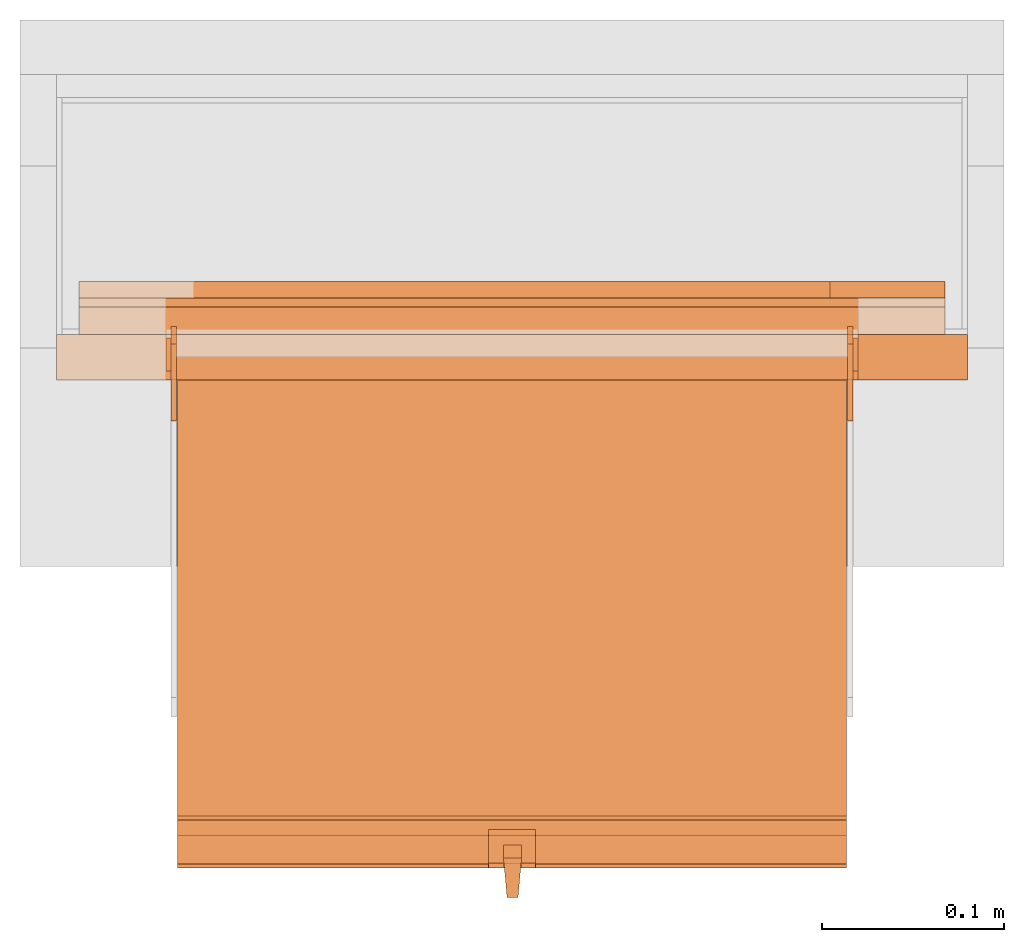
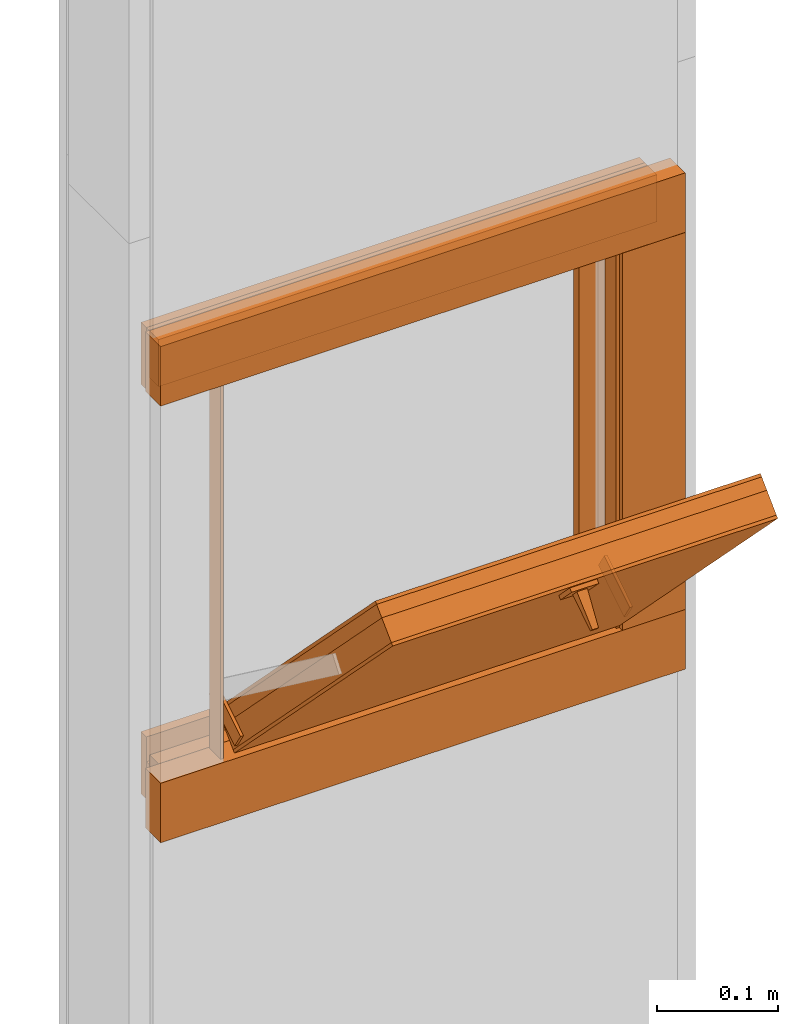
# One storey, part 2 of 3: 20 proxies.
"""IFC2X3 building model written with IfcOpenShell, lengths in metres."""

from ifc_helpers import new_model, entity, si_unit, converted_unit, derived_unit, money_unit, direction, frame, origin_with_axes, place, context, subcontext, project, spatial, polyline, outline, extrude, faceted_brep, source, transform, mapped, material, type_object, element, save


model = new_model("IFC2X3")

# Units and contexts
model_context = context("Model", 3, precision=1e-05, world=origin_with_axes(), true_north=direction((0.0, 1.0)))
plan_context = context("Plan", 3, precision=1e-05, world=origin_with_axes(), true_north=direction((0.0, 1.0)))
body_context = subcontext(model_context, "Body", "Model", "MODEL_VIEW")
ifc_project = project(units=[si_unit("LENGTHUNIT", "METRE"), si_unit("AREAUNIT", "SQUARE_METRE"), si_unit("VOLUMEUNIT", "CUBIC_METRE"), converted_unit("PLANEANGLEUNIT", "DEGREE", entity("IfcPlaneAngleMeasure", 0.0174532925199), si_unit("PLANEANGLEUNIT", "RADIAN"), dimensions=[0, 0, 0, 0, 0, 0, 0]), si_unit("SOLIDANGLEUNIT", "STERADIAN"), money_unit("CHF"), converted_unit("TIMEUNIT", "Year", entity("IfcTimeMeasure", 31556926.0), si_unit("TIMEUNIT", "SECOND"), dimensions=[0, 0, 1, 0, 0, 0, 0]), si_unit("MASSUNIT", "GRAM", prefix="KILO"), si_unit("THERMODYNAMICTEMPERATUREUNIT", "DEGREE_CELSIUS"), si_unit("LUMINOUSINTENSITYUNIT", "LUMEN"), si_unit("ENERGYUNIT", "JOULE", prefix="MEGA"), derived_unit("THERMALCONDUCTANCEUNIT", [(si_unit("POWERUNIT", "WATT"), 1), (si_unit("LENGTHUNIT", "METRE"), -1), (si_unit("THERMODYNAMICTEMPERATUREUNIT", "KELVIN"), -1)]), derived_unit("SPECIFICHEATCAPACITYUNIT", [(si_unit("ENERGYUNIT", "JOULE"), 1), (si_unit("MASSUNIT", "GRAM", prefix="KILO"), -1), (si_unit("THERMODYNAMICTEMPERATUREUNIT", "KELVIN"), -1)]), derived_unit("MASSDENSITYUNIT", [(si_unit("MASSUNIT", "GRAM", prefix="KILO"), 1), (si_unit("VOLUMEUNIT", "CUBIC_METRE"), -1)])], contexts=[model_context, plan_context])

# Site, building, storey
site_placement = place(None, origin_with_axes())
site = spatial("IfcSite", under=ifc_project, at=site_placement, CompositionType="ELEMENT")
building_placement = place(site_placement, origin_with_axes())
building = spatial("IfcBuilding", under=site, at=building_placement, CompositionType="ELEMENT")
storey_placement = place(building_placement, origin_with_axes())
storey = spatial("IfcBuildingStorey", under=building, at=storey_placement, Name="EG00", CompositionType="ELEMENT", Elevation=0.0)

# Proxies
ifc_material_1 = material(Name="Holz")
building_element_proxy_type_1 = type_object("IfcBuildingElementProxyType", Name="Holz 15", PredefinedType="NOTDEFINED")
for number, where, z_axis, x_axis, name in (
    (1, (9.60272436818, -3.87378861887, 0.99), (0.0, 0.0, 1.0), (-1.0, 0.0, 0.0), "Wand-004"),
    (2, (9.60272436818, -3.87378861887, 0.5625), (0.0, 0.0, 1.0), (-1.0, 0.0, 0.0), "Wand-004"),
):
    element("IfcBuildingElementProxy", number, at=place(storey_placement, frame(where, z_axis=z_axis, x_axis=x_axis)), inside=storey, type_object=building_element_proxy_type_1, material=ifc_material_1, Name=name, context=body_context, shape_type="SweptSolid", body=[
        extrude(outline(polyline([(0.0, 0.0), (0.475, 0.0), (0.475, 0.015), (0.0, 0.015), (0.0, 0.0)])), origin_with_axes(), (0.0, 0.0, 1.0), 0.0475),
    ])
building_element_proxy_type_2 = type_object("IfcBuildingElementProxyType", Name="Holz 25", PredefinedType="NOTDEFINED")
proxy_1_placement = place(storey_placement, frame((9.55522436818, -3.91378861887, 0.61), z_axis=(0.0, 0.0, 1.0), x_axis=(1.0, 0.0, 0.0)))
element("IfcBuildingElementProxy", 3, at=proxy_1_placement, inside=storey, type_object=building_element_proxy_type_2, material=ifc_material_1, Name="Wand-004", context=body_context, shape_type="SweptSolid", body=[
    extrude(outline(polyline([(0.0, 0.0), (0.06, 0.0), (0.06, 0.025), (0.0, 0.025), (0.0, 0.0)])), origin_with_axes(), (0.0, 0.0, 1.0), 0.38),
])
for number, where, z_axis, x_axis, name in (
    (4, (9.61522436818, -3.88878861887, 0.99), (0.0, 0.0, 1.0), (-1.0, 0.0, 0.0), "Wand-004"),
    (5, (9.61522436818, -3.88878861887, 0.55), (0.0, 0.0, 1.0), (-1.0, 0.0, 0.0), "Wand-004"),
):
    element("IfcBuildingElementProxy", number, at=place(storey_placement, frame(where, z_axis=z_axis, x_axis=x_axis)), inside=storey, type_object=building_element_proxy_type_2, material=ifc_material_1, Name=name, context=body_context, shape_type="SweptSolid", body=[
        extrude(outline(polyline([(0.0, 0.0), (0.5, 0.0), (0.5, 0.025), (0.0, 0.025), (0.0, 0.0)])), origin_with_axes(), (0.0, 0.0, 1.0), 0.06),
    ])
ifc_material_2 = material(Name="Metall, Aluminium")
building_element_proxy_type_3 = type_object("IfcBuildingElementProxyType", Name="Metall, Aluminium", PredefinedType="NOTDEFINED")
shared_shape_1 = source(origin_with_axes(), body_context, "Body", "Brep", [
    faceted_brep([(16.1345115895, -3.59726483298, 0.726478855326), (16.1345115895, -3.60026483298, 0.726478855326), (16.1345115895, -3.60026483298, 0.776478855326), (16.1345115895, -3.59726483298, 0.776478855326), (16.1525115895, -3.60026483298, 0.726478855326), (16.1525115895, -3.59726483298, 0.726478855326), (16.1525115895, -3.60026483298, 0.776478855326), (16.1525115895, -3.59726483298, 0.776478855326)], [[[0, 1, 2, 3]], [[4, 1, 0, 5]], [[1, 4, 6, 2]], [[2, 6, 7, 3]], [[0, 3, 7, 5]], [[4, 5, 7, 6]]]),
])
for number, where, z_axis, x_axis, name in (
    (6, (12.7784892012, -11.8786678245, 14.7145311427), (0.0, -0.846133712697, -0.532970674838), (0.0, 0.532970674838, -0.846133712697), "Wand-005"),
    (7, (13.1494892012, -11.8786678245, 14.7145311427), (0.0, -0.846133712697, -0.532970674838), (0.0, 0.532970674838, -0.846133712697), "Wand-005"),
):
    element("IfcBuildingElementProxy", number, at=place(storey_placement, frame(where, z_axis=z_axis, x_axis=x_axis)), inside=storey, type_object=building_element_proxy_type_3, material=ifc_material_2, Name=name, context=body_context, shape_type="MappedRepresentation", body=[
        mapped(shared_shape_1, transform((0.0, 0.0, 0.0))),
    ])
building_element_proxy_type_4 = type_object("IfcBuildingElementProxyType", Name="Holz 5", PredefinedType="NOTDEFINED")
for number, where, z_axis, x_axis, name in (
    (8, (9.60272436818, -3.87378861887, 1.0), (0.0, 0.0, 1.0), (-1.0, 0.0, 0.0), "Wand-004"),
    (9, (9.60272436818, -3.87378861887, 0.5625), (0.0, 0.0, 1.0), (-1.0, 0.0, 0.0), "Wand-004"),
):
    element("IfcBuildingElementProxy", number, at=place(storey_placement, frame(where, z_axis=z_axis, x_axis=x_axis)), inside=storey, type_object=building_element_proxy_type_4, material=ifc_material_1, Name=name, context=body_context, shape_type="SweptSolid", body=[
        extrude(outline(polyline([(0.0, -0.005), (0.475, -0.005), (0.475, 0.0), (0.0, 0.0), (0.0, -0.005)])), origin_with_axes(), (0.0, 0.0, 1.0), 0.0375),
    ])
building_element_proxy_type_5 = type_object("IfcBuildingElementProxyType", Name="Holz 9", PredefinedType="NOTDEFINED")
proxy_2_placement = place(storey_placement, frame((9.53972436818, -3.86878861887, 0.625), z_axis=(0.0, 0.0, 1.0), x_axis=(1.0, 0.0, 0.0)))
element("IfcBuildingElementProxy", 10, at=proxy_2_placement, inside=storey, type_object=building_element_proxy_type_5, material=ifc_material_1, Name="Wand-004", context=body_context, shape_type="SweptSolid", body=[
    extrude(outline(polyline([(0.0, 0.0), (0.063, 0.0), (0.063, 0.009), (0.0, 0.009), (0.0, 0.0)])), origin_with_axes(), (0.0, 0.0, 1.0), 0.35),
])
for number, where, z_axis, x_axis, name in (
    (11, (9.60272436818, -3.86878861887, 0.975), (0.0, 0.0, 1.0), (-1.0, 0.0, 0.0), "Wand-004"),
    (12, (9.60272436818, -3.86878861887, 0.5625), (0.0, 0.0, 1.0), (-1.0, 0.0, 0.0), "Wand-004"),
):
    element("IfcBuildingElementProxy", number, at=place(storey_placement, frame(where, z_axis=z_axis, x_axis=x_axis)), inside=storey, type_object=building_element_proxy_type_5, material=ifc_material_1, Name=name, context=body_context, shape_type="SweptSolid", body=[
        extrude(outline(polyline([(0.0, -0.009), (0.475, -0.009), (0.475, 0.0), (0.0, 0.0), (0.0, -0.009)])), origin_with_axes(), (0.0, 0.0, 1.0), 0.0625),
    ])
building_element_proxy_type_6 = type_object("IfcBuildingElementProxyType", Name="Metall, Aluminium 3", PredefinedType="NOTDEFINED")
proxy_3_placement = place(storey_placement, frame((9.17522436818, -3.89078861887, 0.61), z_axis=(0.0, 0.0, 1.0), x_axis=(0.0, -1.0, 0.0)))
element("IfcBuildingElementProxy", 13, at=proxy_3_placement, inside=storey, type_object=building_element_proxy_type_6, material=ifc_material_2, Name="Wand-006", context=body_context, shape_type="SweptSolid", body=[
    extrude(outline(polyline([(0.0, 0.0), (0.018, 0.0), (0.018, 0.003), (0.0, 0.003), (0.0, 0.0)])), origin_with_axes(), (0.0, 0.0, 1.0), 0.393521144674),
])
proxy_4_placement = place(storey_placement, frame((9.55522436818, -3.89078861887, 0.61), z_axis=(0.0, 0.0, 1.0), x_axis=(0.0, -1.0, 0.0)))
element("IfcBuildingElementProxy", 14, at=proxy_4_placement, inside=storey, type_object=building_element_proxy_type_6, material=ifc_material_2, Name="Wand-006", context=body_context, shape_type="SweptSolid", body=[
    extrude(outline(polyline([(0.0, -0.003), (0.018, -0.003), (0.018, 0.0), (0.0, 0.0), (0.0, -0.003)])), origin_with_axes(), (0.0, 0.0, 1.0), 0.393521144674),
])
shared_shape_2 = source(origin_with_axes(), body_context, "Body", "Brep", [
    faceted_brep([(16.3888858635, -3.43025891523, 1.114), (16.3888858635, -3.43025891523, 1.14), (16.3888858635, -3.40425891523, 1.14), (16.3888858635, -3.40425891523, 1.114), (16.3928858635, -3.43025891523, 1.114), (16.3928858635, -3.43025891523, 1.14), (16.3928858635, -3.40825891523, 1.14), (16.3928858635, -3.40425891523, 1.14), (16.3928858635, -3.40425891523, 1.114), (16.3928858635, -3.40825891523, 1.114)], [[[0, 1, 2, 3]], [[1, 0, 4]], [[2, 1, 5, 6, 7]], [[3, 2, 7, 8]], [[0, 3, 8, 9, 4]], [[1, 4, 5]], [[6, 5, 4]], [[6, 9, 8, 7]], [[9, 6, 4]]]),
])
proxy_5_placement = place(storey_placement, frame((12.7824832834, 8.31945325966, 11.5470677443), z_axis=(0.0, -0.700249431637, 0.713898265506), x_axis=(0.0, -0.713898265506, -0.700249431637)))
element("IfcBuildingElementProxy", 15, at=proxy_5_placement, inside=storey, type_object=building_element_proxy_type_3, material=ifc_material_2, Name="Wand-007", context=body_context, shape_type="MappedRepresentation", body=[
    mapped(shared_shape_2, transform((0.0, 0.0, 0.0))),
])
shared_shape_3 = source(origin_with_axes(), body_context, "Body", "Brep", [
    faceted_brep([(16.3891379247, -3.43334637562, 1.097), (16.3891379247, -3.44334637562, 1.097), (16.3921379247, -3.43534637562, 1.13058255688), (16.3991379247, -3.43334637562, 1.097), (16.3991379247, -3.44334637562, 1.097), (16.3921379247, -3.44134637562, 1.13058255688), (16.3961379247, -3.43523159518, 1.13058255688), (16.3961379247, -3.4414517679, 1.13058255688)], [[[0, 1, 2]], [[1, 0, 3, 4]], [[1, 5, 2]], [[0, 2, 3]], [[4, 3, 6]], [[5, 1, 4]], [[2, 5, 7]], [[3, 2, 6]], [[6, 7, 4]], [[7, 5, 4]], [[2, 7, 6]]]),
])
proxy_6_placement = place(storey_placement, frame((12.8038684551, -14.8694200011, 13.3444423362), z_axis=(0.0, -0.713898265506, -0.700249431636), x_axis=(0.0, 0.700249431636, -0.713898265506)))
element("IfcBuildingElementProxy", 16, at=proxy_6_placement, inside=storey, type_object=building_element_proxy_type_3, material=ifc_material_2, Name="Wand-008", context=body_context, shape_type="MappedRepresentation", body=[
    mapped(shared_shape_3, transform((0.0, 0.0, 0.0))),
])
shared_shape_4 = source(origin_with_axes(), body_context, "Body", "Brep", [
    faceted_brep([(16.1060766769, -3.29167330347, 0.736478855326), (16.1060766769, -3.65867330347, 0.736478855326), (16.1060766769, -3.65867330347, 1.10947885533), (16.1060766769, -3.29167330347, 1.10947885533), (16.1091136769, -3.29167330347, 0.736478855326), (16.1091136769, -3.65867330347, 0.736478855326), (16.1091136769, -3.65867330347, 1.10947885533), (16.1091136769, -3.29167330347, 1.10947885533)], [[[0, 1, 2, 3]], [[1, 0, 4, 5]], [[2, 1, 5, 6]], [[3, 2, 6, 7]], [[0, 3, 7, 4]], [[5, 4, 7, 6]]]),
])
proxy_7_placement = place(storey_placement, frame((12.8403976717, 8.09555096902, 11.375802015), z_axis=(0.0, -0.700249431637, 0.713898265506), x_axis=(0.0, -0.713898265506, -0.700249431637)))
element("IfcBuildingElementProxy", 17, at=proxy_7_placement, inside=storey, type_object=building_element_proxy_type_3, material=ifc_material_2, Name="Wand-004", context=body_context, shape_type="MappedRepresentation", body=[
    mapped(shared_shape_4, transform((0.0, 0.0, 0.0))),
])
building_element_proxy_type_7 = type_object("IfcBuildingElementProxyType", Name="Holz", PredefinedType="NOTDEFINED")
shared_shape_5 = source(origin_with_axes(), body_context, "Body", "Brep", [
    faceted_brep([(16.0840766769, -3.65867330347, 1.10947885533), (16.0840766769, -3.29167330347, 1.10947885533), (16.0840766769, -3.29167330347, 0.736478855326), (16.0840766769, -3.65867330347, 0.736478855326), (16.1060766769, -3.65867330347, 1.10947885533), (16.1060766769, -3.29167330347, 1.10947885533), (16.1060766769, -3.29167330347, 0.736478855326), (16.1060766769, -3.65867330347, 0.736478855326)], [[[0, 1, 2, 3]], [[1, 0, 4, 5]], [[2, 1, 5, 6]], [[3, 2, 6, 7]], [[0, 3, 7, 4]], [[4, 7, 6, 5]]]),
])
proxy_8_placement = place(storey_placement, frame((12.8403976717, 8.09555096902, 11.375802015), z_axis=(0.0, -0.700249431637, 0.713898265506), x_axis=(0.0, -0.713898265506, -0.700249431637)))
element("IfcBuildingElementProxy", 18, at=proxy_8_placement, inside=storey, type_object=building_element_proxy_type_7, material=ifc_material_1, Name="Wand-004", context=body_context, shape_type="MappedRepresentation", body=[
    mapped(shared_shape_5, transform((0.0, 0.0, 0.0))),
])
ifc_material_3 = material(Name="Gipsplatte horizontal")
building_element_proxy_type_8 = type_object("IfcBuildingElementProxyType", Name="Gipsplatte horizontal", PredefinedType="NOTDEFINED")
shared_shape_6 = source(origin_with_axes(), body_context, "Body", "Brep", [
    faceted_brep([(16.0720766769, -3.65867330347, 1.10947885533), (16.0720766769, -3.29167330347, 1.10947885533), (16.0720766769, -3.29167330347, 0.736478855326), (16.0720766769, -3.65867330347, 0.736478855326), (16.0840766769, -3.65867330347, 1.10947885533), (16.0840766769, -3.29167330347, 1.10947885533), (16.0840766769, -3.29167330347, 0.736478855326), (16.0840766769, -3.65867330347, 0.736478855326)], [[[0, 1, 2, 3]], [[1, 0, 4, 5]], [[2, 1, 5, 6]], [[3, 2, 6, 7]], [[0, 3, 7, 4]], [[4, 7, 6, 5]]]),
])
proxy_9_placement = place(storey_placement, frame((12.8403976717, 8.09555096902, 11.375802015), z_axis=(0.0, -0.700249431637, 0.713898265506), x_axis=(0.0, -0.713898265506, -0.700249431637)))
element("IfcBuildingElementProxy", 19, at=proxy_9_placement, inside=storey, type_object=building_element_proxy_type_8, material=ifc_material_3, Name="Wand-004", context=body_context, shape_type="MappedRepresentation", body=[
    mapped(shared_shape_6, transform((0.0, 0.0, 0.0))),
])
shared_shape_7 = source(origin_with_axes(), body_context, "Body", "Brep", [
    faceted_brep([(16.0690396769, -3.29167330347, 0.736478855326), (16.0690396769, -3.65867330347, 0.736478855326), (16.0690396769, -3.65867330347, 1.10947885533), (16.0690396769, -3.29167330347, 1.10947885533), (16.0720766769, -3.29167330347, 0.736478855326), (16.0720766769, -3.65867330347, 0.736478855326), (16.0720766769, -3.65867330347, 1.10947885533), (16.0720766769, -3.29167330347, 1.10947885533)], [[[0, 1, 2, 3]], [[1, 0, 4, 5]], [[2, 1, 5, 6]], [[3, 2, 6, 7]], [[0, 3, 7, 4]], [[5, 4, 7, 6]]]),
])
proxy_10_placement = place(storey_placement, frame((12.8403976717, 8.09555096902, 11.375802015), z_axis=(0.0, -0.700249431637, 0.713898265506), x_axis=(0.0, -0.713898265506, -0.700249431637)))
element("IfcBuildingElementProxy", 20, at=proxy_10_placement, inside=storey, type_object=building_element_proxy_type_3, material=ifc_material_2, Name="Wand-004", context=body_context, shape_type="MappedRepresentation", body=[
    mapped(shared_shape_7, transform((0.0, 0.0, 0.0))),
])

save(model, "model.ifc")
